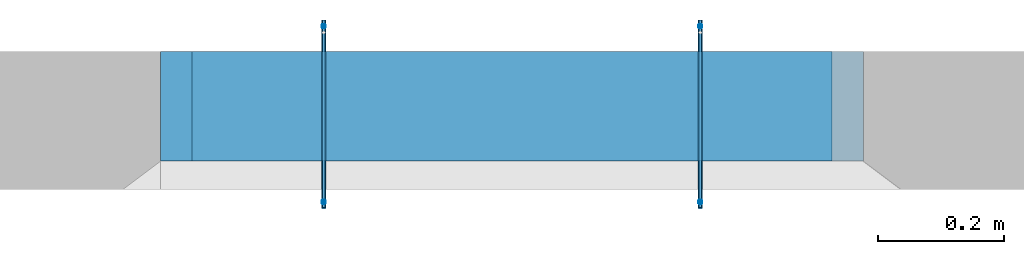
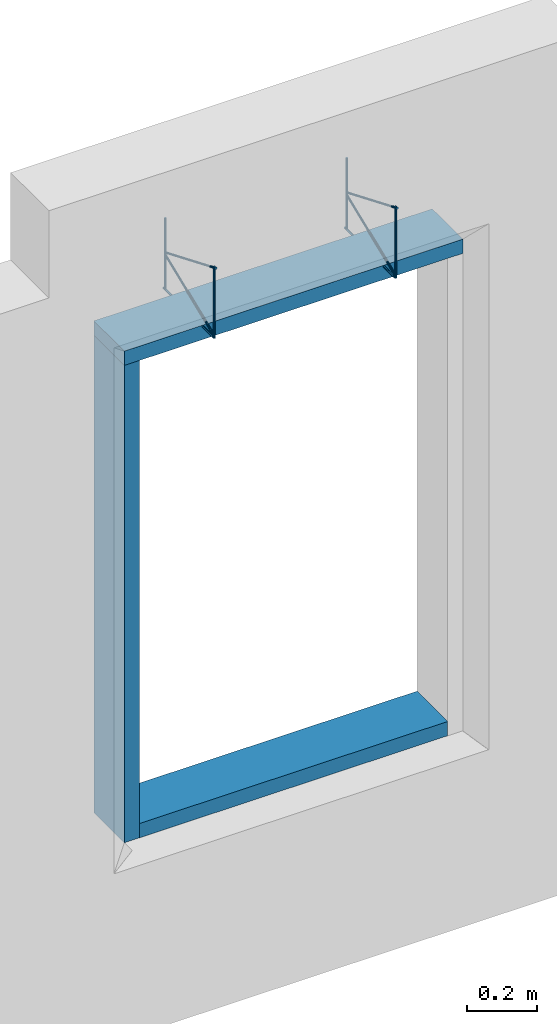
# One storey, part 3 of 4: 4 reinforcing bars, 3 beams, 5 elements without a shape of their own.
"""IFC2X3 building model written with IfcOpenShell, lengths in millimetres."""

from ifc_helpers import new_model, entity, si_unit, frame, origin_with_axes, origin_2d_with_axis, place, context, subcontext, project, spatial, rectangle, extrude, source, transform, mapped, material, type_object, element, aggregate, save


model = new_model("IFC2X3")

# Units and contexts
model_context = context("Model", 3, precision=1e-05, world=origin_with_axes())
body_context = subcontext(model_context, "Body", "Model", "MODEL_VIEW")
ifc_project = project(units=[si_unit("LENGTHUNIT", "METRE", prefix="MILLI"), si_unit("AREAUNIT", "SQUARE_METRE"), si_unit("VOLUMEUNIT", "CUBIC_METRE"), si_unit("MASSUNIT", "GRAM", prefix="KILO"), si_unit("TIMEUNIT", "SECOND"), si_unit("PLANEANGLEUNIT", "RADIAN"), si_unit("SOLIDANGLEUNIT", "STERADIAN"), si_unit("THERMODYNAMICTEMPERATUREUNIT", "DEGREE_CELSIUS"), si_unit("LUMINOUSINTENSITYUNIT", "LUMEN")], contexts=[model_context])

# Site, building, storey
site_placement = place(None, origin_with_axes())
site = spatial("IfcSite", under=ifc_project, at=site_placement, CompositionType="ELEMENT")
building_placement = place(site_placement, origin_with_axes())
building = spatial("IfcBuilding", under=site, at=building_placement, Name="C", CompositionType="ELEMENT")
storey_placement = place(building_placement, origin_with_axes())
storey = spatial("IfcBuildingStorey", under=building, at=storey_placement, Name="2", CompositionType="ELEMENT", Elevation=0.0)

# Assembly, beam
assembly_1_placement = place(storey_placement, origin_with_axes())
assembly_1 = element("IfcElementAssembly", 1, at=assembly_1_placement, inside=storey, AssemblyPlace="NOTDEFINED", PredefinedType="NOTDEFINED")
ifc_material_1 = material(Name="TIMBER/C24")
beam_type = type_object("IfcBeamType", Name="175X50", PredefinedType="NOTDEFINED")
beam_1_placement = place(assembly_1_placement, frame((22635.9944799607, 12282.496011353, 675.000000000014), z_axis=(0.0, -1.0, 0.0), x_axis=(1.0, 0.0, 0.0)))
beam_1 = element("IfcBeam", 2, at=beam_1_placement, type_object=beam_type, material=ifc_material_1, ObjectType="175X50", context=body_context, shape_type="SweptSolid", body=[
    extrude(rectangle(XDim=50.0, YDim=175.0, at=origin_2d_with_axis()), frame((1020.00000000034, 1.13686837721616e-13, 0.0), z_axis=(-1.0, 0.0, 0.0), x_axis=(0.0, -1.0, 0.0)), (0.0, 0.0, 1.0), 1020.0),
])
aggregate(assembly_1, [beam_1])

assembly_2_placement = place(storey_placement, origin_with_axes())
assembly_2 = element("IfcElementAssembly", 3, at=assembly_2_placement, inside=storey, AssemblyPlace="NOTDEFINED", PredefinedType="NOTDEFINED")
beam_2_placement = place(assembly_2_placement, frame((22610.9945037605, 12282.496011353, 2320.00000000001), z_axis=(0.0, -1.0, 0.0), x_axis=(0.0, 0.0, -1.0)))
beam_2 = element("IfcBeam", 4, at=beam_2_placement, type_object=beam_type, material=ifc_material_1, ObjectType="175X50", context=body_context, shape_type="SweptSolid", body=[
    extrude(rectangle(XDim=50.0, YDim=175.0, at=origin_2d_with_axis()), frame((1670.0, 0.0, 0.0), z_axis=(-1.0, 0.0, 0.0), x_axis=(0.0, -1.0, 0.0)), (0.0, 0.0, 1.0), 1670.0),
])
aggregate(assembly_2, [beam_2])

assembly_3_placement = place(storey_placement, origin_with_axes())
assembly_3 = element("IfcElementAssembly", 5, at=assembly_3_placement, inside=storey, AssemblyPlace="NOTDEFINED", PredefinedType="NOTDEFINED")
beam_3_placement = place(assembly_3_placement, frame((23705.9944799609, 12282.4963023938, 2345.00000000001), z_axis=(0.0, -1.0, 0.0), x_axis=(-1.0, 0.0, 0.0)))
beam_3 = element("IfcBeam", 6, at=beam_3_placement, type_object=beam_type, material=ifc_material_1, ObjectType="175X50", context=body_context, shape_type="SweptSolid", body=[
    extrude(rectangle(XDim=50.0, YDim=175.0, at=origin_2d_with_axis()), frame((1120.00000000038, 0.0, 0.0), z_axis=(-1.0, 0.0, 0.0), x_axis=(0.0, -1.0, 0.0)), (0.0, 0.0, 1.0), 1120.0),
])
aggregate(assembly_3, [beam_3])

# Assembly, reinforcing bars
assembly_4_placement = place(storey_placement, origin_with_axes())
assembly_4 = element("IfcElementAssembly", 7, at=assembly_4_placement, inside=storey, Name="Steel Assembly", AssemblyPlace="NOTDEFINED", PredefinedType="RIGID_FRAME")
ifc_material_2 = material(Name="Undefined")
shared_shape_1 = source(origin_with_axes(), body_context, "Body", "AdvancedSweptSolid", [
    entity("IfcSweptDiskSolid", entity("IfcTrimmedCurve", entity("IfcLine", entity("IfcCartesianPoint", [0.0, 0.0, 0.0]), entity("IfcVector", entity("IfcDirection", [1.0, 0.0, 0.0]), 1.0)), [entity("IfcParameterValue", 0.0)], [entity("IfcParameterValue", 250.0)], True, "PARAMETER"), 3.5, None, 0.0, 250.0),
])
shared_shape_2 = source(origin_with_axes(), body_context, "Body", "AdvancedSweptSolid", [
    entity("IfcSweptDiskSolid", entity("IfcTrimmedCurve", entity("IfcLine", entity("IfcCartesianPoint", [0.0, 0.0, 0.0]), entity("IfcVector", entity("IfcDirection", [1.0, 0.0, 0.0]), 1.0)), [entity("IfcParameterValue", 0.0)], [entity("IfcParameterValue", 250.0)], True, "PARAMETER"), 3.5, None, 0.0, 250.0),
])
reinforcing_bar_1_placement = place(assembly_4_placement, frame((22845.9999984589, 12229.997138942, 2370.68890158898), z_axis=(1.0, 0.0, 0.0), x_axis=(0.0, 0.0, 1.0)))
reinforcing_bar_1 = element("IfcReinforcingBar", 8, at=reinforcing_bar_1_placement, material=ifc_material_2, BarRole="NOTDEFINED", CrossSectionArea=0.0, NominalDiameter=7.0, context=body_context, shape_type="MappedRepresentation", body=[
    mapped(shared_shape_1, transform((-5.6889015889833, -180.000000000047, 8.36735125631094e-11))),
    mapped(shared_shape_2, transform((-5.6889015889833, 99.9999999999745, 7.27595761418343e-12))),
])
shared_shape_3 = source(origin_with_axes(), body_context, "Body", "AdvancedSweptSolid", [
    entity("IfcSweptDiskSolid", entity("IfcCompositeCurve", [entity("IfcCompositeCurveSegment", "CONTINUOUS", True, entity("IfcTrimmedCurve", entity("IfcLine", entity("IfcCartesianPoint", [0.0, 0.0, 0.0]), entity("IfcVector", entity("IfcDirection", [-0.73019384278766, 1.20358421436666e-10, -0.683240039777375]), 1.0)), [entity("IfcParameterValue", 0.0)], [entity("IfcParameterValue", 281.652872477378)], True, "PARAMETER")), entity("IfcCompositeCurveSegment", "CONTINUOUS", True, entity("IfcTrimmedCurve", entity("IfcCircle", entity("IfcAxis2Placement3D", entity("IfcCartesianPoint", [-201.903373067664, 3.38884102918999e-08, -196.452585930188]), entity("IfcDirection", [0.0, -1.0, 0.0]), entity("IfcDirection", [-0.683240039777375, 1.97906046910308e-12, 0.730193842787661])), 5.5), [entity("IfcParameterValue", 0.0)], [entity("IfcParameterValue", 2.75830850584735)], True, "PARAMETER")), entity("IfcCompositeCurveSegment", "CONTINUOUS", True, entity("IfcTrimmedCurve", entity("IfcLine", entity("IfcCartesianPoint", [-199.920096320189, 3.41258715586494e-08, -201.582557990826]), entity("IfcVector", entity("IfcDirection", [0.932722192843232, -1.12365497498338e-10, 0.360595772268218]), 1.0)), [entity("IfcParameterValue", 0.0)], [entity("IfcParameterValue", 292.488858542005)], True, "PARAMETER")), entity("IfcCompositeCurveSegment", "CONTINUOUS", True, entity("IfcTrimmedCurve", entity("IfcCircle", entity("IfcAxis2Placement3D", entity("IfcCartesianPoint", [74.8740299487986, 1.52704603978119e-09, -101.24228422566]), entity("IfcDirection", [0.0, 1.0, 0.0]), entity("IfcDirection", [-0.360595772268219, -4.85146516227247e-11, 0.932722192843232])), 5.5), [entity("IfcParameterValue", 0.0)], [entity("IfcParameterValue", 2.36351738609811)], True, "PARAMETER")), entity("IfcCompositeCurveSegment", "DISCONTINUOUS", True, entity("IfcTrimmedCurve", entity("IfcLine", entity("IfcCartesianPoint", [79.8874278952158, 1.28331291046426e-09, -103.504106727728]), entity("IfcVector", entity("IfcDirection", [-0.411240454921447, 1.14087015404707e-10, -0.911526899348561]), 1.0)), [entity("IfcParameterValue", 0.0)], [entity("IfcParameterValue", 311.583087754837)], True, "PARAMETER"))], False), 3.5, None, 0.0, 890.846644666166),
])
reinforcing_bar_2_placement = place(assembly_4_placement, frame((22845.9999404946, 12079.8309133275, 2370.68890158898), z_axis=(2.63999998423969e-07, 0.683240039790062, -0.730193842775742), x_axis=(2.8199999867767e-07, 0.730193842775688, 0.683240039790112)))
reinforcing_bar_2 = element("IfcReinforcingBar", 9, at=reinforcing_bar_2_placement, material=ifc_material_2, BarRole="NOTDEFINED", CrossSectionArea=0.0, NominalDiameter=7.0, context=body_context, shape_type="MappedRepresentation", body=[
    mapped(shared_shape_3, transform((244.500398116423, -3.72419890481979e-08, 236.569186436714))),
])
aggregate(assembly_4, [reinforcing_bar_1, reinforcing_bar_2])

assembly_5_placement = place(storey_placement, origin_with_axes())
assembly_5 = element("IfcElementAssembly", 10, at=assembly_5_placement, inside=storey, Name="Steel Assembly", AssemblyPlace="NOTDEFINED", PredefinedType="RIGID_FRAME")
shared_shape_4 = source(origin_with_axes(), body_context, "Body", "AdvancedSweptSolid", [
    entity("IfcSweptDiskSolid", entity("IfcTrimmedCurve", entity("IfcLine", entity("IfcCartesianPoint", [0.0, 0.0, 0.0]), entity("IfcVector", entity("IfcDirection", [1.0, 0.0, 0.0]), 1.0)), [entity("IfcParameterValue", 0.0)], [entity("IfcParameterValue", 250.0)], True, "PARAMETER"), 3.5, None, 0.0, 250.0),
])
shared_shape_5 = source(origin_with_axes(), body_context, "Body", "AdvancedSweptSolid", [
    entity("IfcSweptDiskSolid", entity("IfcTrimmedCurve", entity("IfcLine", entity("IfcCartesianPoint", [0.0, 0.0, 0.0]), entity("IfcVector", entity("IfcDirection", [1.0, 0.0, 0.0]), 1.0)), [entity("IfcParameterValue", 0.0)], [entity("IfcParameterValue", 250.0)], True, "PARAMETER"), 3.5, None, 0.0, 250.0),
])
reinforcing_bar_3_placement = place(assembly_5_placement, frame((23445.9999984591, 12229.997138942, 2370.68890158898), z_axis=(1.0, 0.0, 0.0), x_axis=(0.0, 0.0, 1.0)))
reinforcing_bar_3 = element("IfcReinforcingBar", 11, at=reinforcing_bar_3_placement, material=ifc_material_2, BarRole="NOTDEFINED", CrossSectionArea=0.0, NominalDiameter=7.0, context=body_context, shape_type="MappedRepresentation", body=[
    mapped(shared_shape_4, transform((-5.6889015889833, -180.000000000047, 8.36735125631094e-11))),
    mapped(shared_shape_5, transform((-5.6889015889833, 99.9999999999745, 7.27595761418343e-12))),
])
shared_shape_6 = source(origin_with_axes(), body_context, "Body", "AdvancedSweptSolid", [
    entity("IfcSweptDiskSolid", entity("IfcCompositeCurve", [entity("IfcCompositeCurveSegment", "CONTINUOUS", True, entity("IfcTrimmedCurve", entity("IfcLine", entity("IfcCartesianPoint", [0.0, 0.0, 0.0]), entity("IfcVector", entity("IfcDirection", [-0.73019384278766, 1.20358421436666e-10, -0.683240039777375]), 1.0)), [entity("IfcParameterValue", 0.0)], [entity("IfcParameterValue", 281.652872477378)], True, "PARAMETER")), entity("IfcCompositeCurveSegment", "CONTINUOUS", True, entity("IfcTrimmedCurve", entity("IfcCircle", entity("IfcAxis2Placement3D", entity("IfcCartesianPoint", [-201.903373067664, 3.38884102918999e-08, -196.452585930188]), entity("IfcDirection", [0.0, -1.0, 0.0]), entity("IfcDirection", [-0.683240039777375, 1.97906046910308e-12, 0.730193842787661])), 5.5), [entity("IfcParameterValue", 0.0)], [entity("IfcParameterValue", 2.75830850584735)], True, "PARAMETER")), entity("IfcCompositeCurveSegment", "CONTINUOUS", True, entity("IfcTrimmedCurve", entity("IfcLine", entity("IfcCartesianPoint", [-199.920096320189, 3.41258715586494e-08, -201.582557990826]), entity("IfcVector", entity("IfcDirection", [0.932722192843232, -1.12365497498338e-10, 0.360595772268218]), 1.0)), [entity("IfcParameterValue", 0.0)], [entity("IfcParameterValue", 292.488858542003)], True, "PARAMETER")), entity("IfcCompositeCurveSegment", "CONTINUOUS", True, entity("IfcTrimmedCurve", entity("IfcCircle", entity("IfcAxis2Placement3D", entity("IfcCartesianPoint", [74.8740299487986, 1.52704603978119e-09, -101.24228422566]), entity("IfcDirection", [0.0, 1.0, 0.0]), entity("IfcDirection", [-0.360595772268219, -4.85146516227247e-11, 0.932722192843232])), 5.5), [entity("IfcParameterValue", 0.0)], [entity("IfcParameterValue", 2.36351738609813)], True, "PARAMETER")), entity("IfcCompositeCurveSegment", "DISCONTINUOUS", True, entity("IfcTrimmedCurve", entity("IfcLine", entity("IfcCartesianPoint", [79.8874278952158, 1.28331291046426e-09, -103.504106727728]), entity("IfcVector", entity("IfcDirection", [-0.411240454921447, 1.14087015404707e-10, -0.911526899348561]), 1.0)), [entity("IfcParameterValue", 0.0)], [entity("IfcParameterValue", 311.583087754837)], True, "PARAMETER"))], False), 3.5, None, 0.0, 890.846644666165),
])
reinforcing_bar_4_placement = place(assembly_5_placement, frame((23445.9999404948, 12079.8309133275, 2370.68890158898), z_axis=(2.63999998423969e-07, 0.683240039790062, -0.730193842775742), x_axis=(2.8199999867767e-07, 0.730193842775688, 0.683240039790112)))
reinforcing_bar_4 = element("IfcReinforcingBar", 12, at=reinforcing_bar_4_placement, material=ifc_material_2, BarRole="NOTDEFINED", CrossSectionArea=0.0, NominalDiameter=7.0, context=body_context, shape_type="MappedRepresentation", body=[
    mapped(shared_shape_6, transform((244.500398116423, -3.72419890481979e-08, 236.569186436714))),
])
aggregate(assembly_5, [reinforcing_bar_3, reinforcing_bar_4])

save(model, "model.ifc")
